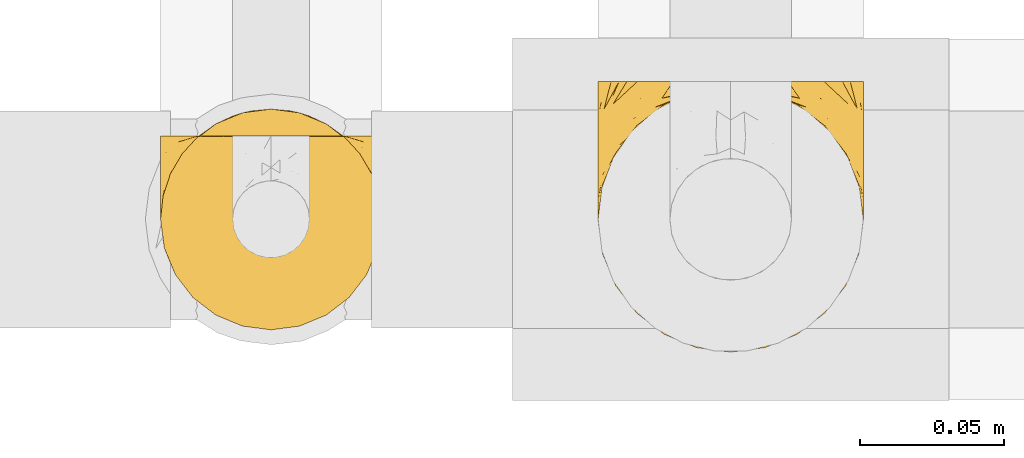
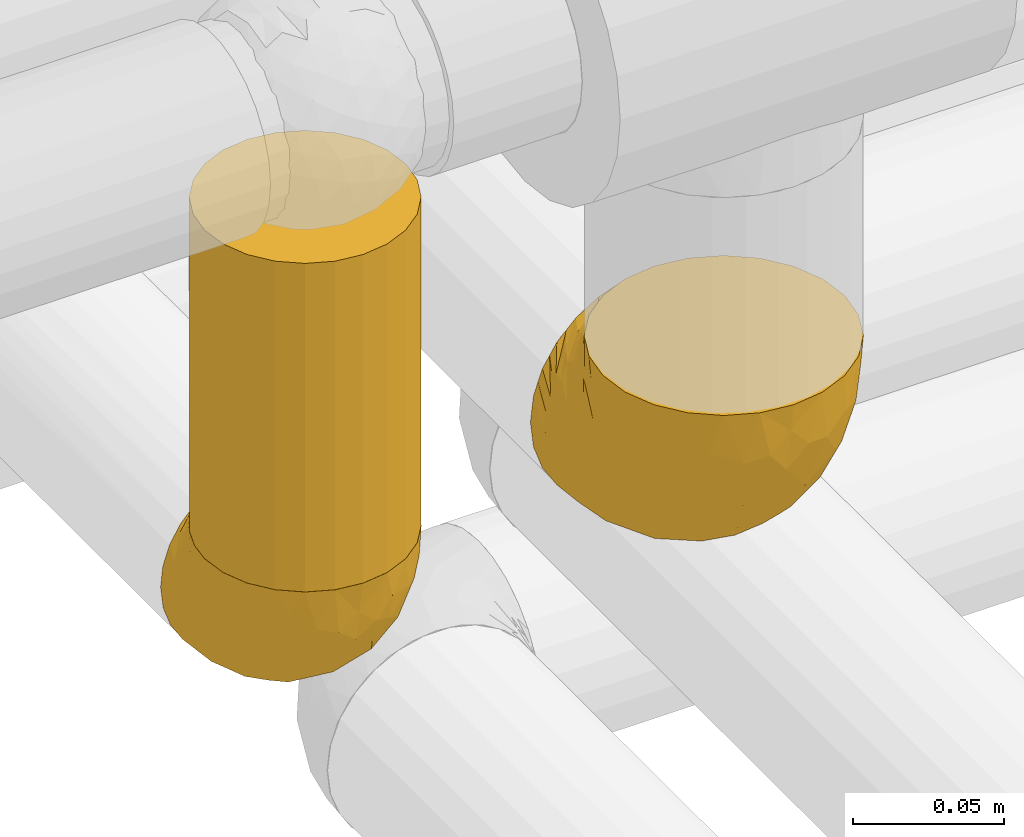
# One storey, part 420 of 827: 3 coverings.
"""IFC2X3 building model written with IfcOpenShell, lengths in millimetres."""

from ifc_helpers import new_model, entity, si_unit, converted_unit, derived_unit, direction, frame, origin, place, context, subcontext, project, spatial, faceted_brep, element, save


model = new_model("IFC2X3")

# Units and contexts
model_context = context("Model", 3, precision=0.01, world=origin(), true_north=direction((6.12303176911189e-17, 1.0)))
body_context = subcontext(model_context, "Body", "Model", "MODEL_VIEW")
ifc_project = project(units=[si_unit("LENGTHUNIT", "METRE", prefix="MILLI"), si_unit("AREAUNIT", "SQUARE_METRE"), si_unit("VOLUMEUNIT", "CUBIC_METRE"), converted_unit("PLANEANGLEUNIT", "DEGREE", entity("IfcRatioMeasure", 0.0174532925199433), si_unit("PLANEANGLEUNIT", "RADIAN"), dimensions=[0, 0, 0, 0, 0, 0, 0]), si_unit("MASSUNIT", "GRAM", prefix="KILO"), derived_unit("MASSDENSITYUNIT", [(si_unit("MASSUNIT", "GRAM", prefix="KILO"), 1), (si_unit("LENGTHUNIT", "METRE"), -3)]), derived_unit("MOMENTOFINERTIAUNIT", [(si_unit("LENGTHUNIT", "METRE"), 4)]), si_unit("TIMEUNIT", "SECOND"), si_unit("FREQUENCYUNIT", "HERTZ"), si_unit("THERMODYNAMICTEMPERATUREUNIT", "DEGREE_CELSIUS"), derived_unit("THERMALTRANSMITTANCEUNIT", [(si_unit("MASSUNIT", "GRAM", prefix="KILO"), 1), (si_unit("THERMODYNAMICTEMPERATUREUNIT", "KELVIN"), -1), (si_unit("TIMEUNIT", "SECOND"), -3)]), derived_unit("VOLUMETRICFLOWRATEUNIT", [(si_unit("LENGTHUNIT", "METRE"), 3), (si_unit("TIMEUNIT", "SECOND"), -1)]), derived_unit("MASSFLOWRATEUNIT", [(si_unit("MASSUNIT", "GRAM", prefix="KILO"), 1), (si_unit("TIMEUNIT", "SECOND"), -1)]), derived_unit("ROTATIONALFREQUENCYUNIT", [(si_unit("TIMEUNIT", "SECOND"), -1)]), si_unit("ELECTRICCURRENTUNIT", "AMPERE"), si_unit("ELECTRICVOLTAGEUNIT", "VOLT"), si_unit("POWERUNIT", "WATT"), si_unit("FORCEUNIT", "NEWTON", prefix="KILO"), si_unit("ILLUMINANCEUNIT", "LUX"), si_unit("LUMINOUSFLUXUNIT", "LUMEN"), si_unit("LUMINOUSINTENSITYUNIT", "CANDELA"), derived_unit("USERDEFINED", [(si_unit("MASSUNIT", "GRAM", prefix="KILO"), -1), (si_unit("LENGTHUNIT", "METRE"), -2), (si_unit("TIMEUNIT", "SECOND"), 3), (si_unit("LUMINOUSFLUXUNIT", "LUMEN"), 1)]), derived_unit("LINEARVELOCITYUNIT", [(si_unit("LENGTHUNIT", "METRE"), 1), (si_unit("TIMEUNIT", "SECOND"), -1)]), si_unit("PRESSUREUNIT", "PASCAL"), derived_unit("USERDEFINED", [(si_unit("LENGTHUNIT", "METRE"), -2), (si_unit("MASSUNIT", "GRAM", prefix="KILO"), 1), (si_unit("TIMEUNIT", "SECOND"), -2)]), derived_unit("LINEARFORCEUNIT", [(si_unit("MASSUNIT", "GRAM", prefix="KILO"), 1), (si_unit("LENGTHUNIT", "METRE"), 1), (si_unit("TIMEUNIT", "SECOND"), -2), (si_unit("LENGTHUNIT", "METRE"), -1)]), derived_unit("PLANARFORCEUNIT", [(si_unit("MASSUNIT", "GRAM", prefix="KILO"), 1), (si_unit("LENGTHUNIT", "METRE"), 1), (si_unit("TIMEUNIT", "SECOND"), -2), (si_unit("LENGTHUNIT", "METRE"), -2)])], contexts=[model_context])

# Site, building, storey
site_placement = place(None, origin())
site = spatial("IfcSite", under=ifc_project, at=site_placement, CompositionType="ELEMENT")
building_placement = place(site_placement, origin())
building = spatial("IfcBuilding", under=site, at=building_placement, CompositionType="ELEMENT")
storey_placement = place(building_placement, frame((0.0, 0.0, 28200.0)))
storey = spatial("IfcBuildingStorey", under=building, at=storey_placement, Name="08", CompositionType="ELEMENT", Elevation=28200.0)

# Coverings
covering_1_placement = place(storey_placement, frame((54021.99, 15874.58, 2452.2)))
element("IfcCovering", 1, at=covering_1_placement, inside=storey, Name=":ADSK_", ObjectType=":ADSK_", PredefinedType="INSULATION", context=body_context, shape_type="Brep", body=[
    faceted_brep([(83.91, 95.8, 18.98), (76.59, 95.8, 11.67), (67.83, 95.8, 6.17), (58.07, 95.8, 2.75), (47.8, 95.8, 1.6), (37.51, 95.8, 2.75), (27.74, 95.8, 6.17), (18.98, 95.8, 11.68), (11.67, 95.8, 19.0), (6.17, 95.8, 27.76), (2.75, 95.8, 37.52), (1.6, 95.8, 47.8), (2.06, 95.8, 51.94), (2.41, 95.8, 55.01), (2.75, 95.8, 58.08), (4.46, 95.8, 62.96), (6.17, 95.8, 67.85), (8.93, 95.8, 72.23), (11.68, 95.8, 76.61), (15.34, 95.8, 80.26), (19.0, 95.8, 83.92), (27.76, 95.8, 89.42), (32.64, 95.8, 91.13), (37.52, 95.8, 92.84), (47.8, 95.8, 94.0), (58.08, 95.8, 92.84), (62.96, 95.8, 91.13), (67.85, 95.8, 89.42), (76.61, 95.8, 83.91), (80.26, 95.8, 80.25), (83.92, 95.8, 76.59), (86.67, 95.8, 72.21), (89.42, 95.8, 67.83), (91.13, 95.8, 62.95), (92.84, 95.8, 58.07), (93.18, 95.8, 55.0), (93.53, 95.8, 51.94), (94.0, 95.8, 47.8), (92.84, 95.8, 37.51), (89.42, 95.8, 27.74), (47.8, 94.0, 95.8), (35.84, 92.42, 95.8), (24.7, 87.81, 95.8), (19.91, 84.13, 95.8), (15.13, 80.46, 95.8), (11.46, 75.68, 95.8), (7.78, 70.9, 95.8), (5.48, 65.32, 95.8), (3.17, 59.75, 95.8), (2.69, 56.14, 95.8), (2.42, 54.06, 95.8), (2.14, 51.97, 95.8), (1.6, 47.8, 95.8), (3.17, 35.84, 95.8), (7.78, 24.7, 95.8), (15.13, 15.13, 95.8), (24.7, 7.78, 95.8), (35.84, 3.17, 95.8), (47.8, 1.6, 95.8), (59.75, 3.17, 95.8), (70.9, 7.78, 95.8), (80.46, 15.13, 95.8), (87.81, 24.7, 95.8), (92.42, 35.84, 95.8), (94.0, 47.8, 95.8), (93.45, 51.97, 95.8), (92.9, 56.14, 95.8), (92.42, 59.75, 95.8), (90.11, 65.32, 95.8), (87.81, 70.9, 95.8), (84.13, 75.68, 95.8), (80.46, 80.46, 95.8), (75.68, 84.13, 95.8), (70.9, 87.81, 95.8), (59.75, 92.42, 95.8), (71.98, 15.84, 60.58), (63.6, 6.99, 74.11), (59.72, 14.39, 51.59), (47.8, 6.21, 66.69), (55.16, 4.26, 76.19), (47.8, 3.39, 84.43), (63.76, 31.2, 31.2), (72.22, 26.47, 42.88), (74.18, 11.44, 79.41), (92.52, 47.66, 60.7), (94.0, 61.85, 61.85), (94.0, 59.25, 65.75), (94.0, 56.65, 69.64), (94.0, 54.05, 73.53), (94.0, 51.45, 77.43), (82.14, 19.8, 74.59), (80.34, 26.22, 54.72), (87.52, 31.58, 64.18), (79.59, 38.36, 37.94), (78.25, 51.54, 25.89), (85.01, 51.6, 34.73), (90.25, 55.97, 42.89), (93.2, 62.88, 49.83), (87.23, 41.35, 48.58), (85.55, 82.24, 22.41), (93.0, 40.88, 78.69), (89.31, 29.0, 81.64), (61.31, 74.06, 6.22), (56.86, 54.53, 12.11), (68.34, 57.98, 14.81), (65.71, 43.81, 21.61), (56.99, 38.22, 22.41), (72.15, 38.33, 30.12), (70.34, 74.76, 10.01), (78.36, 76.85, 15.36), (47.8, 84.43, 3.39), (47.8, 40.43, 19.59), (47.8, 30.01, 30.01), (93.06, 78.67, 41.19), (94.0, 92.06, 48.54), (94.0, 88.32, 49.28), (94.0, 85.6, 49.82), (94.0, 82.88, 50.37), (94.0, 80.15, 50.91), (94.0, 77.43, 51.45), (89.88, 76.36, 31.61), (94.0, 50.91, 80.15), (94.0, 50.37, 82.88), (94.0, 49.82, 85.6), (94.0, 49.28, 88.32), (94.0, 48.91, 90.19), (94.0, 48.54, 92.06), (47.8, 66.69, 6.21), (94.0, 73.53, 54.05), (94.0, 69.64, 56.65), (94.0, 65.75, 59.25), (83.7, 66.13, 24.66), (47.8, 19.59, 40.43), (55.9, 24.64, 35.17), (47.8, 53.56, 12.9), (47.8, 12.9, 53.56), (81.75, 82.81, 85.34), (86.43, 81.22, 78.44), (79.8, 86.57, 84.37), (69.84, 92.75, 89.05), (79.5, 89.68, 82.76), (88.08, 72.26, 86.31), (91.6, 64.73, 83.73), (92.93, 62.45, 77.31), (92.43, 60.63, 87.78), (93.24, 56.91, 87.91), (93.36, 58.14, 81.29), (57.25, 93.7, 93.97), (89.41, 83.4, 70.76), (92.89, 75.54, 63.67), (92.66, 79.46, 62.62), (79.58, 82.28, 90.64), (86.51, 76.25, 84.08), (86.29, 84.69, 76.28), (83.91, 90.18, 77.45), (73.94, 86.94, 91.35), (90.94, 65.12, 88.72), (91.94, 71.71, 71.28), (91.98, 75.21, 68.09), (82.79, 78.6, 91.07), (93.16, 87.27, 57.47), (88.76, 87.92, 70.34), (91.89, 86.1, 62.99), (47.8, 94.52, 94.52), (92.22, 66.23, 76.47), (88.56, 91.08, 69.96), (87.72, 71.77, 89.86), (88.33, 76.21, 78.94), (92.18, 68.59, 73.51), (71.78, 89.94, 89.62), (7.27, 76.22, 78.96), (9.17, 81.22, 78.46), (3.66, 71.7, 71.31), (1.6, 49.28, 88.32), (1.6, 48.54, 92.06), (1.6, 50.37, 82.88), (1.6, 49.82, 85.6), (38.35, 93.7, 93.97), (23.84, 89.95, 89.63), (1.6, 82.88, 50.37), (1.6, 85.6, 49.82), (1.6, 92.06, 48.54), (1.6, 88.32, 49.28), (16.1, 89.68, 82.77), (6.84, 87.92, 70.36), (2.66, 62.45, 77.31), (3.37, 66.24, 76.47), (1.6, 56.65, 69.64), (1.6, 59.25, 65.75), (12.8, 78.6, 91.06), (3.16, 60.63, 87.78), (2.35, 56.91, 87.91), (25.77, 92.76, 89.06), (9.09, 76.25, 84.09), (16.02, 82.28, 90.65), (13.85, 82.81, 85.35), (1.6, 54.05, 73.53), (1.6, 51.45, 77.43), (2.23, 58.14, 81.29), (11.69, 90.18, 77.46), (9.31, 84.7, 76.29), (2.43, 87.25, 57.47), (2.71, 75.58, 63.71), (3.61, 75.2, 68.11), (6.18, 83.39, 70.77), (6.77, 90.73, 69.52), (2.93, 79.47, 62.64), (21.66, 86.94, 91.35), (1.6, 65.75, 59.25), (16.09, 86.75, 84.6), (3.7, 86.08, 62.98), (1.6, 77.43, 51.45), (1.6, 73.53, 54.05), (1.6, 69.64, 56.65), (3.99, 64.73, 83.73), (1.6, 50.91, 80.15), (4.65, 65.12, 88.72), (7.51, 72.26, 86.3), (1.6, 61.85, 61.85), (3.43, 68.62, 73.56), (9.46, 74.03, 91.36), (1.6, 80.15, 50.91), (2.4, 49.81, 62.87), (40.43, 4.26, 76.19), (13.57, 19.95, 73.57), (11.3, 30.61, 56.07), (18.65, 25.71, 49.77), (27.26, 22.43, 44.73), (23.61, 15.85, 60.58), (3.07, 60.69, 47.64), (2.69, 40.49, 78.32), (35.87, 14.39, 51.59), (31.99, 6.99, 74.11), (6.71, 29.56, 76.04), (21.41, 11.45, 79.41), (27.24, 57.98, 14.82), (34.26, 74.06, 6.22), (38.73, 54.52, 12.12), (26.97, 43.47, 23.51), (31.83, 31.2, 31.2), (23.4, 33.27, 34.96), (6.91, 64.26, 33.86), (3.4, 74.29, 38.94), (5.84, 80.41, 30.23), (39.69, 24.64, 35.17), (17.6, 73.62, 15.85), (10.38, 78.98, 22.59), (20.6, 53.69, 21.56), (5.36, 42.86, 55.94), (35.73, 41.67, 20.67), (24.84, 79.66, 9.19), (13.87, 58.41, 25.79), (9.06, 47.11, 41.16), (15.99, 38.37, 37.95)], [[[0, 1, 2, 3, 4, 5, 6, 7, 8, 9, 10, 11, 12, 13, 14, 15, 16, 17, 18, 19, 20, 21, 22, 23, 24, 25, 26, 27, 28, 29, 30, 31, 32, 33, 34, 35, 36, 37, 38, 39]], [[40, 41, 42, 43, 44, 45, 46, 47, 48, 49, 50, 51, 52, 53, 54, 55, 56, 57, 58, 59, 60, 61, 62, 63, 64, 65, 66, 67, 68, 69, 70, 71, 72, 73, 74]], [[75, 76, 77]], [[78, 79, 80]], [[77, 81, 82]], [[76, 75, 83]], [[84, 85, 86, 87, 88, 89]], [[90, 91, 92]], [[76, 60, 59]], [[93, 94, 95]], [[90, 62, 61]], [[83, 61, 60]], [[96, 97, 84]], [[98, 93, 95]], [[0, 39, 99]], [[100, 84, 89]], [[62, 101, 63]], [[2, 102, 3]], [[92, 84, 100]], [[103, 102, 104]], [[103, 105, 106]], [[93, 107, 94]], [[1, 108, 2]], [[92, 101, 90]], [[108, 1, 109]], [[102, 110, 3]], [[93, 82, 107]], [[102, 108, 104]], [[111, 106, 112]], [[109, 0, 99]], [[113, 37, 114, 115, 116, 117, 118, 119]], [[120, 38, 113]], [[100, 89, 121, 122, 123, 124, 125, 126, 64]], [[127, 102, 103]], [[97, 119, 128, 129, 130, 85]], [[99, 120, 131]], [[132, 133, 77]], [[59, 80, 79]], [[1, 0, 109]], [[98, 84, 92]], [[94, 109, 131]], [[120, 39, 38]], [[93, 91, 82]], [[104, 94, 105]], [[97, 113, 119]], [[95, 120, 96]], [[83, 90, 61]], [[91, 93, 98]], [[64, 63, 100]], [[100, 63, 101]], [[77, 76, 79]], [[133, 106, 81]], [[84, 97, 85]], [[113, 96, 120]], [[113, 97, 96]], [[37, 113, 38]], [[110, 102, 127]], [[110, 4, 3]], [[103, 111, 134, 127]], [[90, 75, 91]], [[82, 81, 107]], [[91, 75, 82]], [[77, 82, 75]], [[76, 83, 60]], [[90, 83, 75]], [[105, 107, 81]], [[94, 131, 95]], [[105, 94, 107]], [[109, 94, 104]], [[120, 95, 131]], [[98, 95, 96]], [[84, 98, 96]], [[98, 92, 91]], [[106, 105, 81]], [[103, 104, 105]], [[112, 106, 133]], [[103, 106, 111]], [[112, 133, 132]], [[81, 77, 133]], [[77, 78, 135, 132]], [[120, 99, 39]], [[109, 99, 131]], [[59, 58, 80]], [[59, 79, 76]], [[90, 101, 62]], [[100, 101, 92]], [[2, 108, 102]], [[109, 104, 108]], [[78, 77, 79]], [[136, 137, 138]], [[27, 139, 140]], [[141, 142, 143]], [[144, 145, 121]], [[146, 89, 88]], [[147, 139, 25]], [[148, 149, 150]], [[136, 151, 152]], [[147, 40, 74]], [[24, 147, 25]], [[140, 153, 154]], [[33, 116, 34]], [[155, 73, 151]], [[114, 37, 36, 35, 34, 116, 115]], [[146, 156, 144]], [[157, 85, 130]], [[158, 149, 148]], [[151, 159, 152]], [[117, 33, 160]], [[29, 154, 161]], [[155, 74, 73]], [[162, 128, 119]], [[66, 65, 64, 126, 125, 124, 123, 122, 67]], [[163, 147, 24]], [[27, 140, 28]], [[149, 129, 150]], [[139, 27, 26, 25]], [[68, 144, 69]], [[129, 128, 150]], [[164, 87, 86]], [[130, 129, 149]], [[122, 145, 67]], [[154, 153, 148]], [[162, 119, 160]], [[165, 30, 161]], [[150, 161, 148]], [[128, 162, 150]], [[30, 165, 31]], [[145, 144, 68]], [[89, 146, 144]], [[87, 164, 143]], [[166, 156, 142]], [[88, 87, 143]], [[162, 161, 150]], [[161, 30, 29]], [[154, 29, 28]], [[140, 154, 28]], [[161, 154, 148]], [[140, 137, 153]], [[158, 148, 153]], [[157, 130, 158]], [[153, 137, 158]], [[158, 137, 157]], [[167, 137, 136]], [[168, 85, 157]], [[152, 168, 167]], [[167, 168, 157]], [[164, 152, 141]], [[151, 73, 72]], [[152, 167, 136]], [[88, 142, 146]], [[144, 156, 69]], [[146, 142, 156]], [[70, 166, 71]], [[142, 141, 166]], [[70, 69, 156]], [[141, 159, 71]], [[159, 72, 71]], [[138, 137, 140]], [[155, 136, 169]], [[136, 155, 151]], [[74, 155, 169]], [[152, 159, 141]], [[151, 72, 159]], [[168, 152, 164]], [[137, 167, 157]], [[164, 86, 168]], [[85, 168, 86]], [[116, 33, 117]], [[130, 149, 158]], [[67, 145, 68]], [[121, 89, 144]], [[145, 122, 121]], [[40, 147, 163]], [[169, 147, 74]], [[160, 33, 32]], [[162, 160, 32]], [[160, 119, 118, 117]], [[139, 147, 169]], [[139, 169, 138]], [[162, 32, 31]], [[141, 143, 164]], [[88, 143, 142]], [[71, 166, 141]], [[156, 166, 70]], [[139, 138, 140]], [[169, 136, 138]], [[161, 162, 165]], [[162, 31, 165]], [[170, 171, 172]], [[173, 174, 52, 51, 50, 49, 48, 175, 176]], [[177, 178, 41]], [[179, 15, 180]], [[12, 11, 181, 182, 180, 14, 13]], [[183, 21, 20]], [[19, 18, 184]], [[185, 186, 187]], [[186, 188, 187]], [[43, 189, 44]], [[190, 191, 47]], [[23, 22, 21, 192]], [[193, 194, 195]], [[40, 163, 177]], [[196, 197, 198]], [[24, 23, 177]], [[199, 200, 183]], [[201, 15, 179]], [[178, 177, 192]], [[47, 46, 190]], [[202, 203, 204]], [[203, 172, 171]], [[205, 206, 184]], [[207, 41, 178]], [[16, 15, 201]], [[14, 180, 15]], [[204, 203, 200]], [[208, 203, 202]], [[163, 24, 177]], [[48, 47, 191]], [[198, 197, 190]], [[199, 184, 204]], [[171, 195, 209]], [[210, 211, 212]], [[206, 212, 213]], [[205, 17, 210]], [[184, 206, 204]], [[210, 212, 206]], [[185, 196, 214]], [[190, 215, 191]], [[216, 45, 214]], [[186, 217, 193]], [[190, 216, 198]], [[199, 20, 19]], [[196, 185, 187]], [[199, 183, 20]], [[184, 199, 19]], [[199, 204, 200]], [[206, 202, 204]], [[171, 183, 200]], [[203, 208, 172]], [[172, 208, 218]], [[171, 200, 203]], [[218, 188, 219]], [[195, 170, 193]], [[217, 186, 185]], [[193, 219, 186]], [[193, 170, 219]], [[207, 194, 42]], [[217, 220, 189]], [[216, 190, 46]], [[214, 196, 198]], [[44, 220, 45]], [[214, 198, 216]], [[216, 46, 45]], [[214, 45, 220]], [[42, 194, 43]], [[189, 193, 217]], [[207, 195, 194]], [[209, 195, 178]], [[41, 207, 42]], [[195, 207, 178]], [[43, 194, 189]], [[193, 189, 194]], [[171, 170, 195]], [[170, 172, 219]], [[218, 219, 172]], [[188, 186, 219]], [[206, 213, 202]], [[208, 202, 213]], [[201, 210, 16]], [[215, 190, 197]], [[215, 175, 191]], [[175, 48, 191]], [[201, 179, 221, 211]], [[210, 201, 211]], [[23, 192, 177]], [[40, 177, 41]], [[192, 183, 209]], [[21, 183, 192]], [[205, 18, 17]], [[17, 16, 210]], [[217, 185, 214]], [[189, 220, 44]], [[214, 220, 217]], [[192, 209, 178]], [[171, 209, 183]], [[206, 205, 210]], [[18, 205, 184]], [[222, 197, 196, 187, 188, 218]], [[57, 223, 80]], [[224, 225, 226]], [[226, 227, 228]], [[229, 218, 208, 213, 212, 211]], [[230, 52, 174, 173, 176, 175, 215, 197]], [[231, 232, 228]], [[231, 78, 223]], [[223, 57, 232]], [[224, 233, 225]], [[233, 54, 53]], [[234, 232, 56]], [[56, 55, 234]], [[234, 224, 228]], [[235, 236, 237]], [[224, 55, 54]], [[238, 239, 240]], [[52, 230, 53]], [[241, 242, 243]], [[227, 244, 231]], [[11, 10, 242]], [[236, 6, 5]], [[7, 245, 8]], [[8, 246, 9]], [[238, 247, 235]], [[222, 229, 248]], [[242, 211, 221, 179, 180, 182, 181, 11]], [[233, 53, 230]], [[111, 112, 249]], [[250, 6, 236]], [[246, 251, 241]], [[6, 250, 7]], [[127, 236, 110]], [[248, 229, 252]], [[246, 8, 245]], [[235, 245, 250]], [[236, 5, 110]], [[235, 249, 238]], [[237, 236, 127]], [[243, 9, 246]], [[252, 229, 241]], [[56, 232, 57]], [[222, 230, 197]], [[225, 248, 252]], [[248, 233, 230]], [[54, 233, 224]], [[231, 228, 227]], [[244, 132, 231]], [[248, 225, 233]], [[226, 225, 253]], [[235, 250, 236]], [[245, 7, 250]], [[251, 246, 245]], [[243, 246, 241]], [[247, 245, 235]], [[252, 251, 253]], [[229, 222, 218]], [[230, 222, 248]], [[5, 4, 110]], [[237, 127, 134, 111]], [[238, 249, 239]], [[224, 234, 55]], [[232, 234, 228]], [[242, 241, 229]], [[10, 9, 243]], [[211, 242, 229]], [[10, 243, 242]], [[80, 223, 78]], [[80, 58, 57]], [[231, 223, 232]], [[227, 240, 239]], [[224, 226, 228]], [[240, 226, 253]], [[227, 239, 244]], [[226, 240, 227]], [[251, 247, 253]], [[240, 253, 247]], [[249, 235, 237]], [[237, 111, 249]], [[112, 132, 244]], [[112, 244, 249]], [[78, 231, 132, 135]], [[249, 244, 239]], [[247, 238, 240]], [[245, 247, 251]], [[251, 252, 241]], [[225, 252, 253]]]),
])
covering_2_placement = place(storey_placement, frame((53869.79, 15882.38, 2525.67)))
element("IfcCovering", 2, at=covering_2_placement, inside=storey, Name=":ADSK_", ObjectType=":ADSK_", PredefinedType="INSULATION", context=body_context, shape_type="Brep", body=[
    faceted_brep([(77.09, 30.06, 134.33), (78.4, 40.0, 134.33), (77.09, 49.93, 134.33), (73.25, 59.2, 134.33), (67.15, 67.15, 134.33), (59.2, 73.25, 134.33), (49.93, 77.09, 134.33), (40.0, 78.4, 134.33), (30.06, 77.09, 134.33), (20.8, 73.25, 134.33), (12.84, 67.15, 134.33), (6.74, 59.2, 134.33), (2.9, 49.93, 134.33), (1.6, 40.0, 134.33), (2.9, 30.06, 134.33), (6.74, 20.8, 134.33), (12.84, 12.84, 134.33), (20.8, 6.74, 134.33), (30.06, 2.9, 134.33), (40.0, 1.6, 134.33), (49.93, 2.9, 134.33), (59.2, 6.74, 134.33), (67.15, 12.84, 134.33), (73.25, 20.8, 134.33), (70.68, 63.08, 1.6), (74.9, 56.01, 1.6), (77.51, 48.2, 1.6), (78.4, 40.0, 1.6), (77.09, 30.06, 1.6), (73.25, 20.8, 1.6), (67.15, 12.84, 1.6), (59.2, 6.74, 1.6), (49.93, 2.9, 1.6), (40.0, 1.6, 1.6), (30.06, 2.9, 1.6), (20.8, 6.74, 1.6), (12.84, 12.84, 1.6), (6.74, 20.8, 1.6), (2.9, 30.06, 1.6), (1.6, 40.0, 1.6), (2.48, 48.2, 1.6), (5.09, 56.01, 1.6), (9.31, 63.08, 1.6), (14.94, 69.1, 1.6), (65.05, 69.1, 1.6), (59.51, 73.07, 5.57), (53.36, 76.0, 8.5), (46.78, 77.79, 10.29), (40.0, 78.4, 10.9), (33.21, 77.79, 10.29), (26.63, 76.0, 8.5), (20.48, 73.07, 5.57)], [[[0, 1, 2, 3, 4, 5, 6, 7, 8, 9, 10, 11, 12, 13, 14, 15, 16, 17, 18, 19, 20, 21, 22, 23]], [[24, 25, 26, 27, 28, 29, 30, 31, 32, 33, 34, 35, 36, 37, 38, 39, 40, 41, 42, 43, 44]], [[38, 37, 15, 14]], [[39, 38, 14, 13]], [[37, 36, 16, 15]], [[18, 17, 35, 34]], [[19, 18, 34, 33]], [[36, 35, 17, 16]], [[20, 19, 33, 32]], [[21, 20, 32, 31]], [[31, 30, 22, 21]], [[0, 23, 29, 28]], [[1, 0, 28, 27]], [[30, 29, 23, 22]], [[1, 27, 26]], [[2, 26, 25]], [[3, 25, 24]], [[1, 26, 2]], [[2, 25, 3]], [[24, 4, 3]], [[24, 44, 4]], [[44, 45, 5]], [[46, 47, 6]], [[45, 46, 5]], [[5, 46, 6]], [[7, 6, 47]], [[48, 7, 47]], [[44, 5, 4]], [[49, 50, 8]], [[51, 43, 9]], [[50, 51, 9]], [[48, 49, 7]], [[7, 49, 8]], [[50, 9, 8]], [[43, 10, 9]], [[11, 42, 41]], [[12, 41, 40]], [[13, 40, 39]], [[10, 42, 11]], [[11, 41, 12]], [[40, 13, 12]], [[42, 10, 43]], [[51, 50, 49, 48, 47, 46, 45, 44, 43]]]),
])
covering_3_placement = place(storey_placement, frame((53869.74, 15882.33, 2458.12)))
element("IfcCovering", 3, at=covering_3_placement, inside=storey, Name=":ADSK_", ObjectType=":ADSK_", PredefinedType="INSULATION", context=body_context, shape_type="Brep", body=[
    faceted_brep([(74.68, 69.15, 23.36), (70.1, 69.15, 16.07), (64.01, 69.15, 9.98), (56.72, 69.15, 5.4), (48.6, 69.15, 2.56), (40.05, 69.15, 1.6), (31.49, 69.15, 2.56), (23.36, 69.15, 5.41), (16.07, 69.15, 9.99), (9.98, 69.15, 16.08), (5.4, 69.15, 23.37), (2.56, 69.15, 31.49), (1.6, 69.15, 40.05), (2.46, 69.15, 48.15), (5.01, 69.15, 55.88), (9.13, 69.15, 62.9), (14.62, 69.15, 68.89), (16.82, 69.15, 68.89), (18.56, 69.15, 68.89), (20.52, 69.15, 68.89), (22.49, 69.15, 68.89), (24.46, 69.15, 68.89), (26.42, 69.15, 68.89), (28.39, 69.15, 68.89), (30.36, 69.15, 68.89), (32.55, 69.15, 68.89), (34.75, 69.15, 68.89), (36.94, 69.15, 68.89), (39.13, 69.15, 68.89), (41.33, 69.15, 68.89), (43.52, 69.15, 68.89), (45.72, 69.15, 68.89), (47.91, 69.15, 68.89), (50.11, 69.15, 68.89), (52.3, 69.15, 68.89), (54.49, 69.15, 68.89), (56.69, 69.15, 68.89), (58.88, 69.15, 68.89), (61.08, 69.15, 68.89), (63.27, 69.15, 68.89), (65.47, 69.15, 68.89), (70.97, 69.15, 62.89), (75.09, 69.15, 55.86), (77.64, 69.15, 48.13), (78.5, 69.15, 40.05), (77.53, 69.15, 31.49), (14.62, 68.89, 69.15), (9.12, 62.89, 69.15), (5.0, 55.87, 69.15), (2.46, 48.14, 69.15), (1.6, 40.05, 69.15), (2.91, 30.09, 69.15), (6.75, 20.82, 69.15), (12.86, 12.86, 69.15), (20.82, 6.75, 69.15), (30.09, 2.91, 69.15), (40.05, 1.6, 69.15), (50.0, 2.91, 69.15), (59.27, 6.75, 69.15), (67.23, 12.86, 69.15), (73.34, 20.82, 69.15), (77.19, 30.09, 69.15), (78.5, 40.05, 69.15), (77.63, 48.14, 69.15), (75.09, 55.87, 69.15), (70.97, 62.89, 69.15), (65.47, 68.89, 69.15), (63.27, 68.89, 69.15), (62.29, 68.89, 69.15), (60.7, 68.89, 69.15), (59.11, 68.89, 69.15), (57.52, 68.89, 69.15), (55.93, 68.89, 69.15), (54.34, 68.89, 69.15), (52.76, 68.89, 69.15), (51.17, 68.89, 69.15), (49.58, 68.89, 69.15), (47.99, 68.89, 69.15), (46.4, 68.89, 69.15), (44.81, 68.89, 69.15), (43.22, 68.89, 69.15), (41.63, 68.89, 69.15), (40.05, 68.89, 69.15), (38.46, 68.89, 69.15), (36.87, 68.89, 69.15), (35.28, 68.89, 69.15), (33.69, 68.89, 69.15), (32.1, 68.89, 69.15), (30.51, 68.89, 69.15), (28.92, 68.89, 69.15), (27.33, 68.89, 69.15), (25.37, 68.89, 69.15), (23.4, 68.89, 69.15), (21.21, 68.89, 69.15), (19.01, 68.89, 69.15), (16.82, 68.89, 69.15), (42.32, 68.97, 68.96), (44.02, 68.96, 68.97), (47.13, 68.97, 68.97), (48.74, 68.97, 68.97), (23.57, 68.98, 68.95), (25.13, 68.97, 68.96), (61.34, 68.96, 68.98), (22.02, 68.96, 68.97), (29.72, 68.96, 68.97), (56.73, 68.96, 68.98), (55.14, 68.96, 68.97), (37.66, 68.96, 68.97), (64.12, 69.0, 68.94), (28.13, 68.96, 68.98), (26.62, 68.96, 68.98), (31.46, 68.97, 68.96), (16.16, 68.96, 68.97), (39.16, 68.96, 68.98), (50.37, 68.96, 68.98), (17.69, 68.97, 68.97), (19.17, 68.97, 68.96), (62.78, 68.97, 68.97), (58.35, 68.96, 68.97), (45.53, 68.96, 68.98), (59.91, 68.97, 68.96), (65.47, 68.97, 68.97), (65.47, 69.02, 68.94), (65.47, 69.08, 68.92), (14.62, 68.97, 68.97), (14.62, 68.94, 69.02), (14.62, 68.92, 69.08), (20.59, 68.96, 68.98), (32.99, 68.96, 68.97), (34.48, 68.95, 68.98), (51.91, 68.96, 68.97), (65.47, 68.92, 69.08), (65.47, 68.94, 69.02), (53.48, 68.98, 68.96), (14.62, 69.08, 68.92), (14.62, 69.02, 68.94), (40.77, 68.96, 68.97), (35.97, 68.97, 68.96), (7.84, 61.33, 67.02), (3.53, 53.1, 63.33), (8.32, 63.33, 64.61), (2.19, 55.53, 51.4), (3.53, 63.33, 53.1), (1.6, 54.6, 43.94), (1.6, 41.99, 61.87), (4.57, 57.07, 61.54), (3.96, 57.95, 57.95), (2.28, 51.56, 56.12), (1.6, 41.58, 63.4), (7.69, 61.7, 65.41), (8.32, 65.0, 63.04), (7.84, 67.02, 61.33), (1.6, 61.87, 41.99), (1.6, 49.27, 49.27), (1.6, 43.94, 54.6), (4.34, 61.21, 56.6), (1.6, 63.4, 41.58), (29.63, 33.11, 13.72), (27.34, 52.82, 5.82), (40.05, 43.3, 6.74), (2.39, 33.73, 58.82), (2.43, 36.52, 51.58), (9.07, 24.87, 42.09), (16.64, 14.17, 46.12), (9.54, 18.43, 55.56), (4.52, 28.67, 52.38), (4.52, 26.0, 61.54), (7.49, 49.25, 23.76), (7.49, 59.72, 20.5), (12.85, 55.1, 14.64), (2.35, 44.72, 41.77), (22.66, 34.15, 16.28), (32.9, 5.25, 49.4), (25.33, 6.75, 52.34), (40.05, 55.54, 4.3), (16.64, 10.47, 58.67), (19.99, 25.49, 25.26), (16.37, 35.53, 20.17), (3.26, 48.22, 34.7), (3.75, 58.71, 28.67), (19.58, 57.42, 8.62), (7.5, 34.84, 33.37), (4.04, 36.87, 41.35), (13.94, 45.01, 17.15), (19.58, 44.4, 12.68), (28.21, 23.96, 21.47), (24.75, 11.2, 41.11), (31.42, 10.56, 37.53), (26.2, 16.81, 30.64), (33.36, 17.38, 26.66), (40.05, 21.38, 21.38), (40.05, 32.34, 14.06), (40.05, 4.3, 55.54), (16.14, 20.65, 35.17), (12.85, 29.66, 29.04), (10.47, 39.6, 24.34), (6.49, 42.55, 29.33), (40.05, 6.74, 43.3), (40.05, 14.06, 32.34), (75.57, 26.84, 57.75), (47.37, 5.28, 49.41), (52.91, 18.52, 27.85), (50.46, 33.13, 13.7), (67.23, 55.1, 14.63), (60.5, 57.43, 8.61), (70.55, 20.72, 48.85), (63.45, 11.46, 54.13), (62.61, 17.69, 37.84), (72.6, 49.26, 23.75), (72.6, 59.73, 20.49), (76.34, 58.71, 28.66), (59.34, 29.72, 20.83), (77.76, 35.35, 55.15), (78.5, 43.94, 54.6), (78.5, 41.99, 61.87), (78.5, 63.4, 41.58), (53.16, 4.93, 57.58), (70.55, 17.46, 59.91), (48.88, 10.94, 36.94), (54.76, 8.92, 45.72), (52.74, 52.83, 5.82), (71.93, 29.34, 37.91), (75.79, 30.26, 50.18), (60.5, 44.4, 12.67), (77.86, 39.06, 49.29), (77.64, 43.06, 42.64), (78.5, 54.6, 43.94), (78.5, 49.27, 49.27), (67.23, 42.69, 19.45), (76.82, 48.2, 34.7), (78.5, 61.87, 41.99), (77.8, 33.44, 62.29), (67.23, 29.67, 29.01), (73.2, 38.5, 31.47), (67.66, 23.35, 37.18), (75.99, 34.97, 43.45), (76.57, 53.1, 63.33), (73.21, 59.68, 67.23), (71.93, 62.19, 66.07), (71.07, 64.11, 65.22), (75.09, 57.97, 61.99), (76.13, 57.95, 57.95), (76.57, 63.33, 53.09), (77.69, 51.77, 56.84), (72.26, 67.02, 61.33), (71.77, 64.98, 63.06), (77.9, 55.53, 51.41), (75.75, 61.22, 56.61)], [[[0, 1, 2, 3, 4, 5, 6, 7, 8, 9, 10, 11, 12, 13, 14, 15, 16, 17, 18, 19, 20, 21, 22, 23, 24, 25, 26, 27, 28, 29, 30, 31, 32, 33, 34, 35, 36, 37, 38, 39, 40, 41, 42, 43, 44, 45]], [[46, 47, 48, 49, 50, 51, 52, 53, 54, 55, 56, 57, 58, 59, 60, 61, 62, 63, 64, 65, 66, 67, 68, 69, 70, 71, 72, 73, 74, 75, 76, 77, 78, 79, 80, 81, 82, 83, 84, 85, 86, 87, 88, 89, 90, 91, 92, 93, 94, 95]], [[96, 97, 30]], [[98, 77, 99]], [[100, 101, 21]], [[69, 68, 102]], [[20, 19, 103]], [[24, 23, 104]], [[20, 103, 100]], [[72, 105, 106]], [[84, 83, 107]], [[89, 88, 104]], [[108, 67, 66]], [[109, 110, 90]], [[111, 25, 24]], [[112, 17, 16]], [[82, 113, 83]], [[109, 23, 22]], [[114, 76, 75]], [[105, 36, 106]], [[104, 111, 24]], [[18, 115, 116]], [[97, 96, 80]], [[67, 108, 117]], [[105, 71, 118]], [[31, 97, 119]], [[102, 120, 69]], [[108, 121, 122, 123, 40]], [[112, 95, 115]], [[17, 115, 18]], [[94, 116, 115]], [[117, 68, 67]], [[38, 117, 39]], [[112, 124, 125, 126, 46]], [[17, 112, 115]], [[70, 120, 118]], [[39, 117, 108]], [[120, 38, 37]], [[120, 37, 118]], [[120, 70, 69]], [[116, 94, 127]], [[128, 86, 129]], [[117, 38, 102]], [[74, 130, 75]], [[99, 33, 32]], [[115, 95, 94]], [[39, 108, 40]], [[108, 66, 131, 132, 121]], [[105, 72, 71]], [[118, 37, 36]], [[71, 70, 118]], [[35, 106, 36]], [[36, 105, 118]], [[35, 133, 106]], [[74, 73, 133]], [[106, 133, 73]], [[99, 114, 33]], [[133, 35, 34]], [[73, 72, 106]], [[95, 112, 46]], [[112, 16, 134, 135, 124]], [[130, 114, 75]], [[99, 76, 114]], [[114, 130, 33]], [[34, 33, 130]], [[78, 77, 98]], [[98, 119, 78]], [[130, 133, 34]], [[133, 130, 74]], [[79, 97, 80]], [[98, 99, 32]], [[98, 32, 31]], [[77, 76, 99]], [[97, 79, 119]], [[136, 96, 29]], [[30, 97, 31]], [[136, 29, 28]], [[81, 80, 96]], [[29, 96, 30]], [[31, 119, 98]], [[119, 79, 78]], [[96, 136, 81]], [[82, 81, 136]], [[113, 107, 83]], [[84, 107, 137]], [[107, 27, 137]], [[113, 28, 107]], [[27, 107, 28]], [[85, 84, 137]], [[137, 27, 26]], [[113, 136, 28]], [[136, 113, 82]], [[109, 89, 104]], [[86, 85, 129]], [[89, 109, 90]], [[111, 87, 128]], [[26, 129, 137]], [[88, 111, 104]], [[25, 111, 128]], [[22, 110, 109]], [[23, 109, 104]], [[110, 91, 90]], [[100, 92, 101]], [[110, 22, 101]], [[91, 110, 101]], [[116, 19, 18]], [[111, 88, 87]], [[127, 103, 19]], [[25, 128, 26]], [[86, 128, 87]], [[128, 129, 26]], [[137, 129, 85]], [[120, 102, 38]], [[117, 102, 68]], [[91, 101, 92]], [[21, 101, 22]], [[93, 92, 103]], [[100, 21, 20]], [[100, 103, 92]], [[127, 93, 103]], [[93, 127, 94]], [[116, 127, 19]], [[126, 138, 47]], [[48, 138, 139]], [[140, 125, 124]], [[141, 142, 143]], [[144, 49, 139]], [[145, 140, 146]], [[48, 139, 49]], [[139, 145, 147]], [[49, 144, 148, 50]], [[126, 125, 149]], [[14, 13, 142]], [[150, 146, 140]], [[149, 140, 145]], [[151, 150, 135]], [[151, 14, 142]], [[16, 15, 134]], [[13, 152, 142]], [[124, 150, 140]], [[141, 143, 153]], [[14, 151, 15]], [[15, 151, 134]], [[47, 46, 126]], [[139, 154, 144]], [[138, 48, 47]], [[125, 140, 149]], [[135, 134, 151]], [[146, 155, 141]], [[145, 146, 147]], [[149, 139, 138]], [[147, 153, 154]], [[147, 146, 141]], [[139, 147, 154]], [[139, 149, 145]], [[149, 138, 126]], [[147, 141, 153]], [[146, 150, 155]], [[151, 155, 150]], [[142, 141, 155]], [[13, 12, 156, 152]], [[152, 143, 142]], [[151, 142, 155]], [[150, 124, 135]], [[157, 158, 159]], [[160, 154, 161]], [[162, 163, 164]], [[165, 166, 160]], [[167, 168, 169]], [[153, 170, 161]], [[156, 12, 11]], [[158, 157, 171]], [[172, 55, 173]], [[158, 6, 174]], [[175, 54, 53]], [[52, 166, 164]], [[52, 164, 53]], [[54, 175, 173]], [[166, 52, 51]], [[176, 177, 171]], [[178, 143, 179]], [[156, 11, 179]], [[8, 7, 180]], [[169, 9, 8]], [[179, 143, 152, 156]], [[179, 11, 10]], [[168, 179, 10]], [[181, 162, 182]], [[179, 167, 178]], [[183, 184, 177]], [[183, 169, 184]], [[176, 171, 185]], [[172, 186, 187]], [[158, 7, 6]], [[159, 158, 174]], [[184, 180, 158]], [[54, 173, 55]], [[180, 169, 8]], [[188, 189, 187]], [[9, 168, 10]], [[186, 188, 187]], [[190, 157, 159, 191]], [[55, 172, 192]], [[176, 193, 194]], [[161, 170, 182]], [[162, 164, 165]], [[175, 164, 163]], [[51, 50, 148]], [[167, 195, 196]], [[178, 182, 170]], [[6, 5, 174]], [[158, 180, 7]], [[169, 180, 184]], [[169, 168, 9]], [[179, 168, 167]], [[182, 162, 165]], [[162, 194, 193]], [[161, 165, 160]], [[195, 181, 196]], [[192, 172, 197]], [[192, 56, 55]], [[189, 190, 198]], [[198, 197, 187]], [[172, 187, 197]], [[185, 189, 188]], [[198, 187, 189]], [[186, 172, 173]], [[173, 163, 186]], [[193, 186, 163]], [[176, 185, 188]], [[185, 157, 190]], [[188, 186, 193]], [[177, 176, 194]], [[188, 193, 176]], [[162, 193, 163]], [[195, 177, 194]], [[171, 177, 184]], [[181, 195, 194]], [[183, 167, 169]], [[162, 181, 194]], [[196, 182, 178]], [[158, 171, 184]], [[171, 157, 185]], [[177, 195, 183]], [[167, 183, 195]], [[182, 196, 181]], [[178, 170, 143]], [[178, 167, 196]], [[164, 175, 53]], [[173, 175, 163]], [[160, 51, 148]], [[164, 166, 165]], [[51, 160, 166]], [[160, 148, 144, 154]], [[153, 161, 154]], [[182, 165, 161]], [[190, 189, 185]], [[143, 170, 153]], [[60, 199, 61]], [[197, 200, 192]], [[201, 190, 202]], [[200, 57, 192]], [[203, 204, 2]], [[205, 206, 207]], [[208, 209, 210]], [[211, 207, 201]], [[212, 213, 214]], [[45, 215, 210]], [[216, 206, 58]], [[45, 44, 215]], [[59, 217, 60]], [[60, 217, 199]], [[0, 45, 210]], [[218, 201, 219]], [[202, 159, 220]], [[205, 221, 222]], [[223, 204, 203]], [[1, 203, 2]], [[57, 200, 216]], [[220, 3, 204]], [[220, 174, 4]], [[1, 0, 209]], [[212, 224, 213]], [[225, 226, 227]], [[228, 223, 203]], [[208, 210, 229]], [[210, 226, 229]], [[3, 220, 4]], [[58, 206, 59]], [[209, 203, 1]], [[202, 220, 223]], [[228, 203, 208]], [[202, 211, 201]], [[3, 2, 204]], [[202, 190, 191, 159]], [[210, 215, 230, 226]], [[199, 212, 231]], [[232, 233, 221]], [[233, 208, 229]], [[207, 206, 219]], [[217, 206, 205]], [[227, 224, 225]], [[233, 232, 228]], [[201, 207, 219]], [[234, 232, 221]], [[218, 219, 200]], [[202, 223, 211]], [[174, 220, 159]], [[174, 5, 4]], [[61, 231, 62]], [[220, 204, 223]], [[210, 209, 0]], [[203, 209, 208]], [[225, 233, 229]], [[224, 227, 213]], [[221, 233, 235]], [[57, 56, 192]], [[198, 218, 197]], [[200, 219, 216]], [[201, 198, 190]], [[197, 218, 200]], [[198, 201, 218]], [[206, 216, 219]], [[58, 57, 216]], [[231, 212, 214]], [[222, 212, 199]], [[228, 211, 223]], [[207, 211, 232]], [[62, 231, 214]], [[199, 231, 61]], [[233, 228, 208]], [[211, 228, 232]], [[222, 221, 235]], [[234, 205, 207]], [[206, 217, 59]], [[199, 217, 205]], [[205, 222, 199]], [[224, 222, 235]], [[222, 224, 212]], [[224, 235, 225]], [[233, 225, 235]], [[226, 225, 229]], [[205, 234, 221]], [[207, 232, 234]], [[63, 214, 236]], [[214, 213, 236]], [[214, 63, 62]], [[237, 236, 238]], [[238, 132, 131]], [[236, 237, 64]], [[239, 240, 241]], [[63, 236, 64]], [[131, 66, 65]], [[237, 131, 65]], [[242, 230, 43]], [[237, 65, 64]], [[239, 121, 132]], [[42, 242, 43]], [[241, 240, 243]], [[41, 123, 244]], [[43, 230, 215, 44]], [[244, 122, 245]], [[227, 246, 243]], [[241, 247, 245]], [[121, 239, 245]], [[41, 40, 123]], [[132, 238, 239]], [[244, 42, 41]], [[131, 237, 238]], [[240, 239, 238]], [[245, 239, 241]], [[247, 241, 246]], [[247, 244, 245]], [[238, 236, 240]], [[243, 236, 213]], [[236, 243, 240]], [[227, 226, 246]], [[243, 213, 227]], [[242, 246, 226]], [[243, 246, 241]], [[246, 242, 247]], [[244, 247, 242]], [[242, 226, 230]], [[42, 244, 242]], [[122, 244, 123]], [[122, 121, 245]]]),
])

save(model, "model.ifc")
